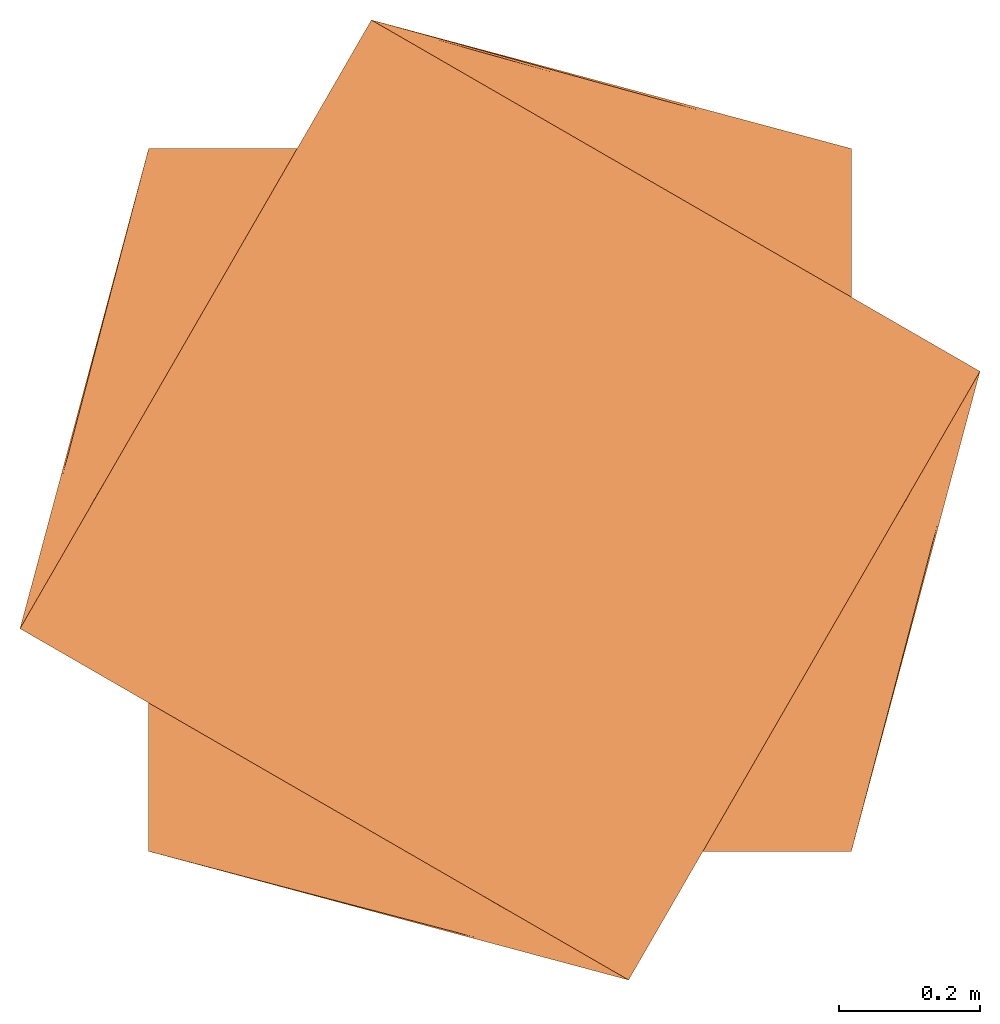
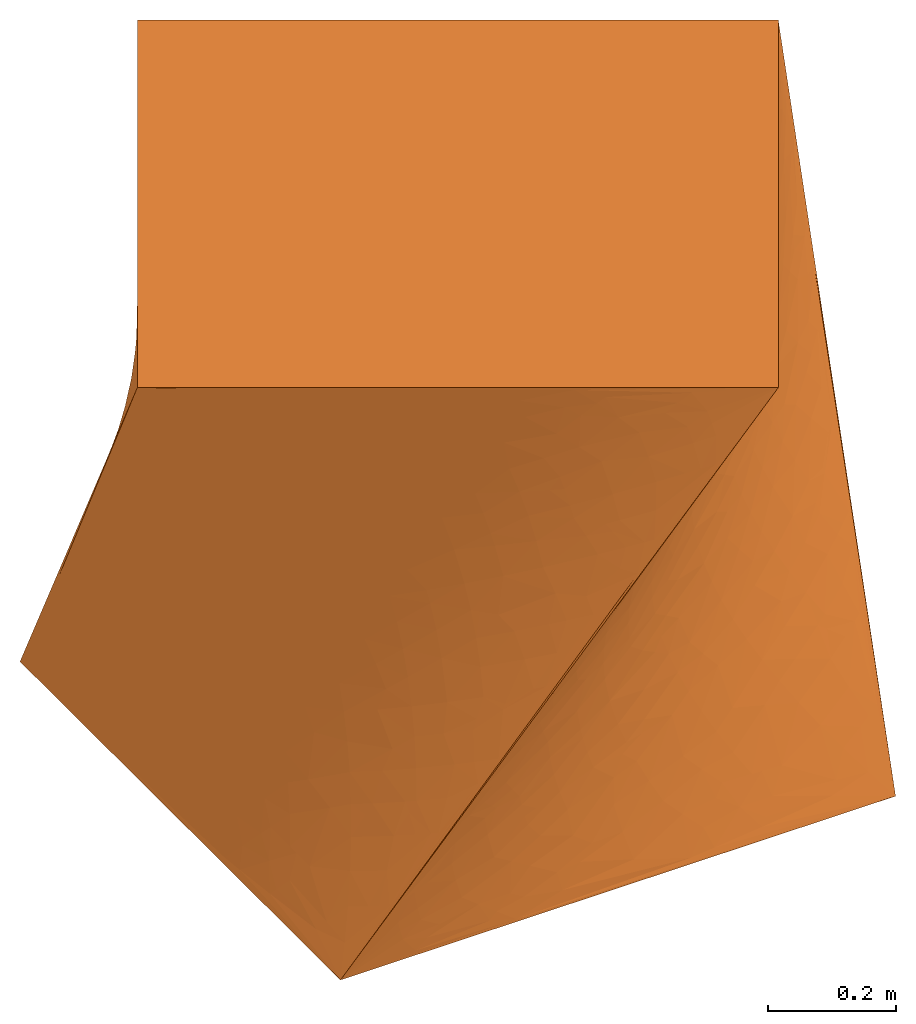
# Not in any storey: 1 proxy.
"""IFC4 building model written with IfcOpenShell, lengths in metres."""

from ifc_helpers import new_model, entity, si_unit, direction, origin_with_axes, place, context, project, spatial, element, save


model = new_model("IFC4")

# Units and contexts
model_context = context("Model", 3, precision=1e-05, world=origin_with_axes(), true_north=direction((0.0, 1.0)), identifier="Body")
ifc_project = project(units=[si_unit("LENGTHUNIT", "METRE"), si_unit("AREAUNIT", "SQUARE_METRE"), si_unit("VOLUMEUNIT", "CUBIC_METRE"), si_unit("PLANEANGLEUNIT", "RADIAN")], contexts=[model_context])

# Building
building_placement = place(None, origin_with_axes())
building = spatial("IfcBuilding", under=ifc_project, at=building_placement, Name="Building", CompositionType="ELEMENT")

# Proxy
proxy_placement = place(None, origin_with_axes())
vertex_point_1 = entity("IfcVertexPoint", entity("IfcCartesianPoint", [-0.5, -0.5, 0.0]))
vertex_point_2 = entity("IfcVertexPoint", entity("IfcCartesianPoint", [-0.5, 0.5, 0.0]))
edge_curve_1 = entity("IfcEdgeCurve", vertex_point_1, vertex_point_2, entity("IfcPolyline", [entity("IfcCartesianPoint", [-0.5, -0.5]), entity("IfcCartesianPoint", [-0.5, 0.5])]), True)
vertex_point_3 = entity("IfcVertexPoint", entity("IfcCartesianPoint", [0.5, 0.5, 0.0]))
edge_curve_2 = entity("IfcEdgeCurve", vertex_point_2, vertex_point_3, entity("IfcPolyline", [entity("IfcCartesianPoint", [-0.5, 0.5]), entity("IfcCartesianPoint", [0.5, 0.5])]), True)
vertex_point_4 = entity("IfcVertexPoint", entity("IfcCartesianPoint", [0.5, -0.5, 0.0]))
edge_curve_3 = entity("IfcEdgeCurve", vertex_point_3, vertex_point_4, entity("IfcPolyline", [entity("IfcCartesianPoint", [0.5, 0.5]), entity("IfcCartesianPoint", [0.5, -0.5])]), True)
edge_curve_4 = entity("IfcEdgeCurve", vertex_point_4, vertex_point_1, entity("IfcPolyline", [entity("IfcCartesianPoint", [0.5, -0.5]), entity("IfcCartesianPoint", [-0.5, -0.5])]), True)
vertex_point_5 = entity("IfcVertexPoint", entity("IfcCartesianPoint", [-0.683012701892219, -0.183012701892219, 1.0]))
vertex_point_6 = entity("IfcVertexPoint", entity("IfcCartesianPoint", [0.183012701892219, -0.683012701892219, 1.0]))
edge_curve_5 = entity("IfcEdgeCurve", vertex_point_5, vertex_point_6, entity("IfcPolyline", [entity("IfcCartesianPoint", [-0.683012701892219, -0.183012701892219, 1.0]), entity("IfcCartesianPoint", [0.183012701892219, -0.683012701892219, 1.0])]), True)
vertex_point_7 = entity("IfcVertexPoint", entity("IfcCartesianPoint", [0.683012701892219, 0.183012701892219, 1.0]))
edge_curve_6 = entity("IfcEdgeCurve", vertex_point_6, vertex_point_7, entity("IfcPolyline", [entity("IfcCartesianPoint", [0.183012701892219, -0.683012701892219, 1.0]), entity("IfcCartesianPoint", [0.683012701892219, 0.183012701892219, 1.0])]), True)
vertex_point_8 = entity("IfcVertexPoint", entity("IfcCartesianPoint", [-0.183012701892219, 0.683012701892219, 1.0]))
edge_curve_7 = entity("IfcEdgeCurve", vertex_point_7, vertex_point_8, entity("IfcPolyline", [entity("IfcCartesianPoint", [0.683012701892219, 0.183012701892219, 1.0]), entity("IfcCartesianPoint", [-0.183012701892219, 0.683012701892219, 1.0])]), True)
edge_curve_8 = entity("IfcEdgeCurve", vertex_point_8, vertex_point_5, entity("IfcPolyline", [entity("IfcCartesianPoint", [-0.183012701892219, 0.683012701892219, 1.0]), entity("IfcCartesianPoint", [-0.683012701892219, -0.183012701892219, 1.0])]), True)
edge_curve_9 = entity("IfcEdgeCurve", vertex_point_2, vertex_point_5, entity("IfcPolyline", [entity("IfcCartesianPoint", [-0.5, 0.5, 0.0]), entity("IfcCartesianPoint", [-0.683012701892219, -0.183012701892219, 1.0])]), True)
edge_curve_10 = entity("IfcEdgeCurve", vertex_point_1, vertex_point_6, entity("IfcPolyline", [entity("IfcCartesianPoint", [-0.5, -0.5, 0.0]), entity("IfcCartesianPoint", [0.183012701892219, -0.683012701892219, 1.0])]), True)
edge_curve_11 = entity("IfcEdgeCurve", vertex_point_4, vertex_point_7, entity("IfcPolyline", [entity("IfcCartesianPoint", [0.5, -0.5, 0.0]), entity("IfcCartesianPoint", [0.683012701892219, 0.183012701892219, 1.0])]), True)
edge_curve_12 = entity("IfcEdgeCurve", vertex_point_3, vertex_point_8, entity("IfcPolyline", [entity("IfcCartesianPoint", [0.5, 0.5, 0.0]), entity("IfcCartesianPoint", [-0.183012701892219, 0.683012701892219, 1.0])]), True)
element("IfcBuildingElementProxy", 1, at=proxy_placement, inside=building, PredefinedType="NOTDEFINED", context=model_context, shape_type="AdvancedBrep", body=[
    entity("IfcAdvancedBrep", entity("IfcClosedShell", [entity("IfcAdvancedFace", [entity("IfcFaceOuterBound", entity("IfcEdgeLoop", [entity("IfcOrientedEdge", None, None, edge_curve_1, True), entity("IfcOrientedEdge", None, None, edge_curve_2, True), entity("IfcOrientedEdge", None, None, edge_curve_3, True), entity("IfcOrientedEdge", None, None, edge_curve_4, True)]), True)], entity("IfcPlane", entity("IfcAxis2Placement3D", entity("IfcCartesianPoint", [-0.5, -0.5, 0.0]), entity("IfcDirection", [0.0, 0.0, -1.0]), entity("IfcDirection", [1.0, 0.0, 0.0]))), True), entity("IfcAdvancedFace", [entity("IfcFaceOuterBound", entity("IfcEdgeLoop", [entity("IfcOrientedEdge", None, None, edge_curve_5, True), entity("IfcOrientedEdge", None, None, edge_curve_6, True), entity("IfcOrientedEdge", None, None, edge_curve_7, True), entity("IfcOrientedEdge", None, None, edge_curve_8, True)]), True)], entity("IfcPlane", entity("IfcAxis2Placement3D", entity("IfcCartesianPoint", [-0.683012701892219, -0.183012701892219, 1.0]), entity("IfcDirection", [0.0, 0.0, 1.0]), entity("IfcDirection", [-0.5, -0.8660254, 0.0]))), True), entity("IfcAdvancedFace", [entity("IfcFaceOuterBound", entity("IfcEdgeLoop", [entity("IfcOrientedEdge", None, None, edge_curve_9, True), entity("IfcOrientedEdge", None, None, edge_curve_5, True), entity("IfcOrientedEdge", None, None, edge_curve_10, False), entity("IfcOrientedEdge", None, None, edge_curve_1, True)]), True)], entity("IfcBSplineSurfaceWithKnots", 3, 1, [[entity("IfcCartesianPoint", [-0.5, 0.5, 0.0]), entity("IfcCartesianPoint", [-0.5, -0.5, 0.0])], [entity("IfcCartesianPoint", [-0.561004233964073, 0.27232909936926, 0.333333333333333]), entity("IfcCartesianPoint", [-0.27232909936926, -0.561004233964073, 0.333333333333333])], [entity("IfcCartesianPoint", [-0.622008467928146, 0.0446581987385206, 0.666666666666667]), entity("IfcCartesianPoint", [-0.0446581987385206, -0.622008467928146, 0.666666666666667])], [entity("IfcCartesianPoint", [-0.683012701892219, -0.183012701892219, 1.0]), entity("IfcCartesianPoint", [0.183012701892219, -0.683012701892219, 1.0])]], "UNSPECIFIED", False, False, "UNKNOWN", [4, 4], [2, 2], [0.0, 1224.74487139159], [3.0, 4.0], "UNSPECIFIED"), False), entity("IfcAdvancedFace", [entity("IfcFaceOuterBound", entity("IfcEdgeLoop", [entity("IfcOrientedEdge", None, None, edge_curve_4, True), entity("IfcOrientedEdge", None, None, edge_curve_10, True), entity("IfcOrientedEdge", None, None, edge_curve_6, True), entity("IfcOrientedEdge", None, None, edge_curve_11, False)]), True)], entity("IfcBSplineSurfaceWithKnots", 3, 1, [[entity("IfcCartesianPoint", [-0.5, -0.5, 0.0]), entity("IfcCartesianPoint", [0.5, -0.5, 0.0])], [entity("IfcCartesianPoint", [-0.27232909936926, -0.561004233964073, 0.333333333333333]), entity("IfcCartesianPoint", [0.561004233964073, -0.27232909936926, 0.333333333333333])], [entity("IfcCartesianPoint", [-0.0446581987385206, -0.622008467928146, 0.666666666666667]), entity("IfcCartesianPoint", [0.622008467928146, -0.0446581987385206, 0.666666666666667])], [entity("IfcCartesianPoint", [0.183012701892219, -0.683012701892219, 1.0]), entity("IfcCartesianPoint", [0.683012701892219, 0.183012701892219, 1.0])]], "UNSPECIFIED", False, False, "UNKNOWN", [4, 4], [2, 2], [0.0, 1224.74487139159], [0.0, 1.0], "UNSPECIFIED"), False), entity("IfcAdvancedFace", [entity("IfcFaceOuterBound", entity("IfcEdgeLoop", [entity("IfcOrientedEdge", None, None, edge_curve_3, True), entity("IfcOrientedEdge", None, None, edge_curve_11, True), entity("IfcOrientedEdge", None, None, edge_curve_7, True), entity("IfcOrientedEdge", None, None, edge_curve_12, False)]), True)], entity("IfcBSplineSurfaceWithKnots", 3, 1, [[entity("IfcCartesianPoint", [0.5, -0.5, 0.0]), entity("IfcCartesianPoint", [0.5, 0.5, 0.0])], [entity("IfcCartesianPoint", [0.561004233964073, -0.27232909936926, 0.333333333333333]), entity("IfcCartesianPoint", [0.27232909936926, 0.561004233964073, 0.333333333333333])], [entity("IfcCartesianPoint", [0.622008467928146, -0.0446581987385206, 0.666666666666667]), entity("IfcCartesianPoint", [0.0446581987385206, 0.622008467928146, 0.666666666666667])], [entity("IfcCartesianPoint", [0.683012701892219, 0.183012701892219, 1.0]), entity("IfcCartesianPoint", [-0.183012701892219, 0.683012701892219, 1.0])]], "UNSPECIFIED", False, False, "UNKNOWN", [4, 4], [2, 2], [0.0, 1224.74487139159], [1.0, 2.0], "UNSPECIFIED"), False), entity("IfcAdvancedFace", [entity("IfcFaceOuterBound", entity("IfcEdgeLoop", [entity("IfcOrientedEdge", None, None, edge_curve_2, True), entity("IfcOrientedEdge", None, None, edge_curve_12, True), entity("IfcOrientedEdge", None, None, edge_curve_8, True), entity("IfcOrientedEdge", None, None, edge_curve_9, False)]), True)], entity("IfcBSplineSurfaceWithKnots", 3, 1, [[entity("IfcCartesianPoint", [0.5, 0.5, 0.0]), entity("IfcCartesianPoint", [-0.5, 0.5, 0.0])], [entity("IfcCartesianPoint", [0.27232909936926, 0.561004233964073, 0.333333333333333]), entity("IfcCartesianPoint", [-0.561004233964073, 0.27232909936926, 0.333333333333333])], [entity("IfcCartesianPoint", [0.0446581987385206, 0.622008467928146, 0.666666666666667]), entity("IfcCartesianPoint", [-0.622008467928146, 0.0446581987385206, 0.666666666666667])], [entity("IfcCartesianPoint", [-0.183012701892219, 0.683012701892219, 1.0]), entity("IfcCartesianPoint", [-0.683012701892219, -0.183012701892219, 1.0])]], "UNSPECIFIED", False, False, "UNKNOWN", [4, 4], [2, 2], [0.0, 1224.74487139159], [2.0, 3.0], "UNSPECIFIED"), False)])),
])

save(model, "model.ifc")
